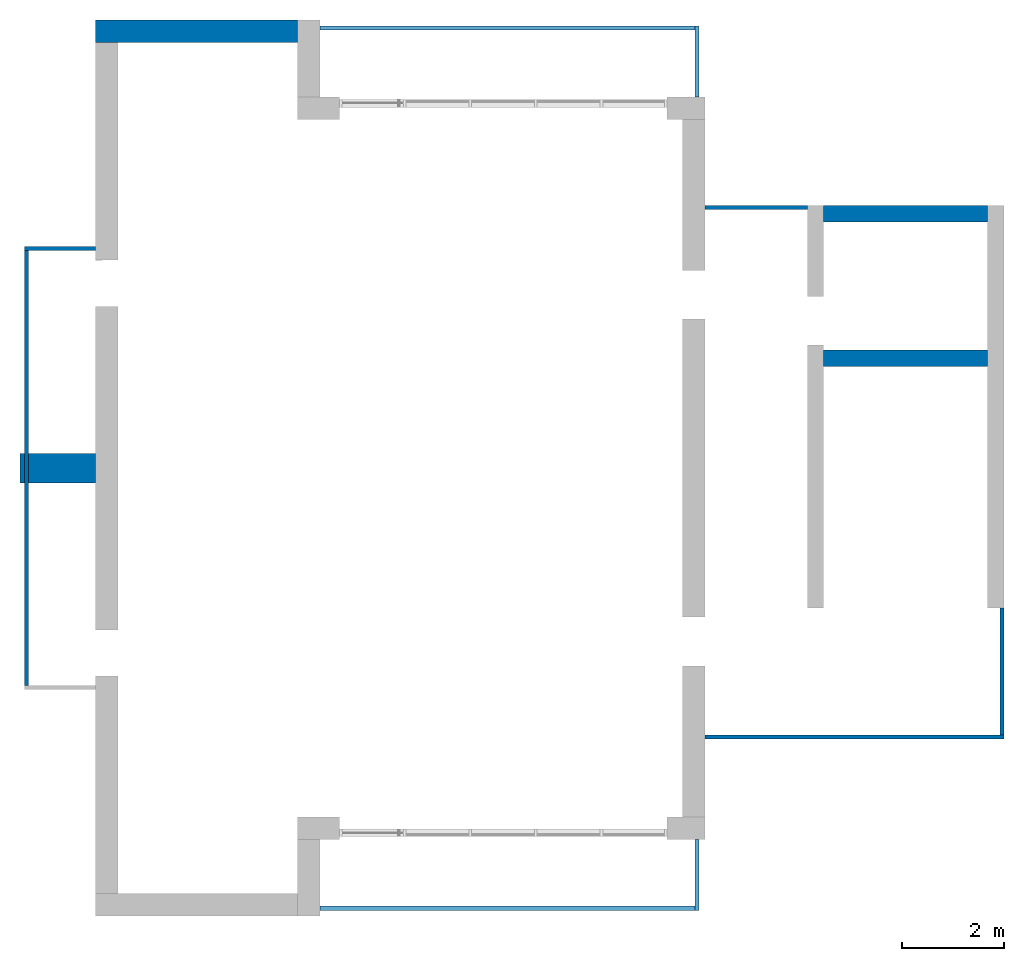
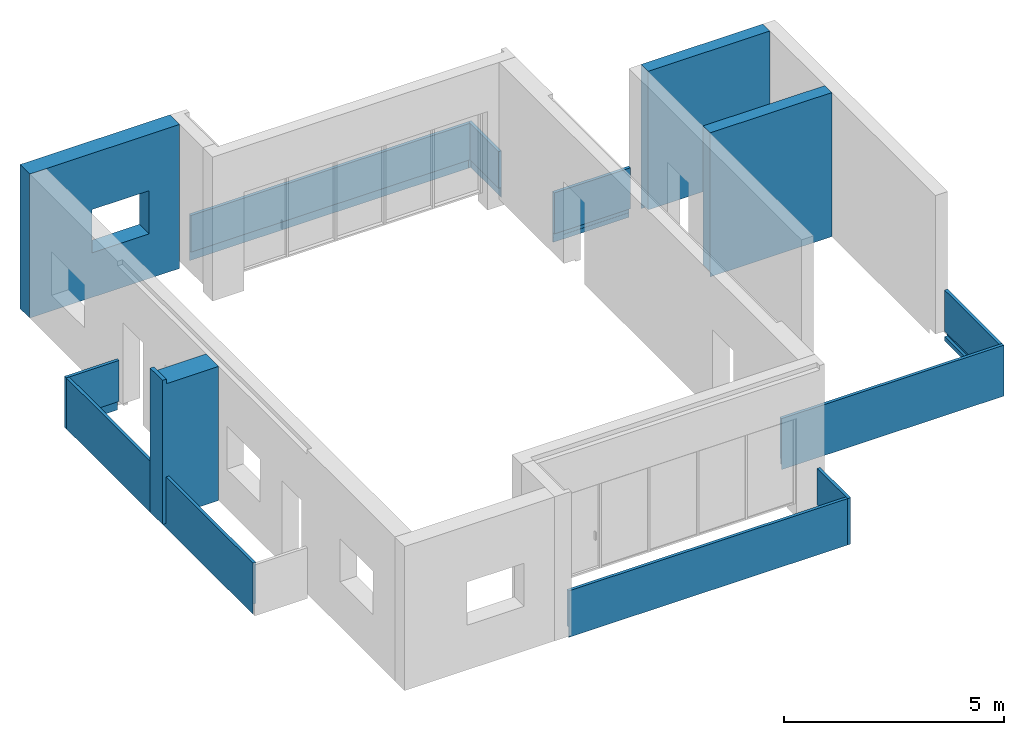
# One storey, part 2 of 4: 13 walls, 1 opening.
"""IFC2X3 building model written with IfcOpenShell, lengths in millimetres."""

from ifc_helpers import new_model, entity, si_unit, converted_unit, derived_unit, direction, frame, frame_2d, origin, place, context, subcontext, project, spatial, polyline, rectangle, extrude, clip, bounded_halfspace, faceted_brep, material, layer, layer_set, layer_usage, type_object, element, save


model = new_model("IFC2X3")

# Units and contexts
model_context = context("Model", 3, precision=0.01, world=origin(), true_north=direction((6.12303176911189e-17, 1.0)))
body_context = subcontext(model_context, "Body", "Model", "MODEL_VIEW")
ifc_project = project(units=[si_unit("LENGTHUNIT", "METRE", prefix="MILLI"), si_unit("AREAUNIT", "SQUARE_METRE"), si_unit("VOLUMEUNIT", "CUBIC_METRE"), converted_unit("PLANEANGLEUNIT", "DEGREE", entity("IfcRatioMeasure", 0.0174532925199433), si_unit("PLANEANGLEUNIT", "RADIAN"), dimensions=[0, 0, 0, 0, 0, 0, 0]), si_unit("MASSUNIT", "GRAM", prefix="KILO"), derived_unit("MASSDENSITYUNIT", [(si_unit("MASSUNIT", "GRAM", prefix="KILO"), 1), (si_unit("LENGTHUNIT", "METRE"), -3)]), si_unit("TIMEUNIT", "SECOND"), si_unit("FREQUENCYUNIT", "HERTZ"), si_unit("THERMODYNAMICTEMPERATUREUNIT", "DEGREE_CELSIUS"), derived_unit("THERMALTRANSMITTANCEUNIT", [(si_unit("MASSUNIT", "GRAM", prefix="KILO"), 1), (si_unit("THERMODYNAMICTEMPERATUREUNIT", "KELVIN"), -1), (si_unit("TIMEUNIT", "SECOND"), -3)]), derived_unit("VOLUMETRICFLOWRATEUNIT", [(si_unit("LENGTHUNIT", "METRE"), 3), (si_unit("TIMEUNIT", "SECOND"), -1)]), si_unit("ELECTRICCURRENTUNIT", "AMPERE"), si_unit("ELECTRICVOLTAGEUNIT", "VOLT"), si_unit("POWERUNIT", "WATT"), si_unit("FORCEUNIT", "NEWTON", prefix="KILO"), si_unit("ILLUMINANCEUNIT", "LUX"), si_unit("LUMINOUSFLUXUNIT", "LUMEN"), si_unit("LUMINOUSINTENSITYUNIT", "CANDELA"), derived_unit("USERDEFINED", [(si_unit("MASSUNIT", "GRAM", prefix="KILO"), -1), (si_unit("LENGTHUNIT", "METRE"), -2), (si_unit("TIMEUNIT", "SECOND"), 3), (si_unit("LUMINOUSFLUXUNIT", "LUMEN"), 1)]), derived_unit("LINEARVELOCITYUNIT", [(si_unit("LENGTHUNIT", "METRE"), 1), (si_unit("TIMEUNIT", "SECOND"), -1)]), si_unit("PRESSUREUNIT", "PASCAL"), derived_unit("USERDEFINED", [(si_unit("LENGTHUNIT", "METRE"), -2), (si_unit("MASSUNIT", "GRAM", prefix="KILO"), 1), (si_unit("TIMEUNIT", "SECOND"), -2)])], contexts=[model_context])

# Site, building, storey
site_placement = place(None, origin())
site = spatial("IfcSite", under=ifc_project, at=site_placement, CompositionType="ELEMENT")
building_placement = place(site_placement, origin())
building = spatial("IfcBuilding", under=site, at=building_placement, CompositionType="ELEMENT")
storey_placement = place(building_placement, frame((0.0, 0.0, 4000.0)))
storey = spatial("IfcBuildingStorey", under=building, at=storey_placement, Name="01 Level", CompositionType="ELEMENT", Elevation=4000.0)

# Wall, opening
ifc_material_1 = material(Name="03")
ifc_layer_1 = layer(ifc_material_1, 10.0)
ifc_material_2 = material()
ifc_layer_2 = layer(ifc_material_2, 120.0)
ifc_material_3 = material()
ifc_layer_3 = layer(ifc_material_3, 300.0)
ifc_layer_4 = layer(ifc_material_1, 10.0)
ifc_layer_set_1 = layer_set([ifc_layer_1, ifc_layer_2, ifc_layer_3, ifc_layer_4], Name="Basic Wall:00_fal+12 cm")
ifc_layer_usage_1 = layer_usage(ifc_layer_set_1, "AXIS2", "POSITIVE", -220.0)
wall_type_1 = type_object("IfcWallType", Name="Basic Wall:00_fal+12 cm", PredefinedType="STANDARD", material=ifc_layer_set_1)
wall_1_placement = place(storey_placement, frame((20983.4900708518, -60301.2395851399, -340.0), z_axis=(0.0, 0.0, 1.0), x_axis=(-1.0, 0.0, 0.0)))
wall_1 = element("IfcWallStandardCase", 1, at=wall_1_placement, inside=storey, type_object=wall_type_1, material=ifc_layer_usage_1, Name="Basic Wall:00_fal+12 cm", ObjectType="Basic Wall:00_fal+12 cm", context=body_context, shape_type="SweptSolid", body=[
    extrude(rectangle(XDim=3940.00000000004, YDim=440.000000000004, at=frame_2d((1970.00000000002, -1.08002495835535e-12), x_axis=(-1.0, 0.0))), origin(), (0.0, 0.0, 1.0), 4000.0),
])
opening_placement = place(wall_1_placement, frame((2300.0, 1304.0, 1240.0), z_axis=(0.0, 0.0, 1.0), x_axis=(-1.0, 0.0, 0.0)))
element("IfcOpeningElement", 2, at=opening_placement, cuts=wall_1, Name="Basic Wall:00_fal+12 cm", ObjectType="Opening", context=body_context, shape_type="SweptSolid", body=[
    extrude(rectangle(XDim=1200.0, YDim=1500.0, at=frame_2d((1.08002495835535e-12, -5.11590769747272e-13), x_axis=(0.0, 1.0))), frame((750.0, 3048.0, 600.0), z_axis=(0.0, -1.0, 0.0), x_axis=(1.0, 0.0, 0.0)), (0.0, 0.0, 1.0), 3048.0),
])

# Walls
ifc_layer_5 = layer(ifc_material_1, 10.0)
ifc_layer_6 = layer(ifc_material_3, 300.0)
ifc_layer_7 = layer(ifc_material_1, 10.0)
ifc_layer_set_2 = layer_set([ifc_layer_5, ifc_layer_6, ifc_layer_7], Name="Basic Wall:00_fal 300 mm")
ifc_layer_usage_2 = layer_usage(ifc_layer_set_2, "AXIS2", "NEGATIVE", 160.0)
wall_type_2 = type_object("IfcWallType", Name="Basic Wall:00_fal 300 mm", PredefinedType="STANDARD", material=ifc_layer_set_2)
wall_2_placement = place(storey_placement, frame((31263.4900708518, -66685.8241905964, -340.0)))
element("IfcWallStandardCase", 3, at=wall_2_placement, inside=storey, type_object=wall_type_2, material=ifc_layer_usage_2, Name="Basic Wall:00_fal 300 mm", ObjectType="Basic Wall:00_fal 300 mm", context=body_context, shape_type="Clipping", body=[
    clip(clip(extrude(rectangle(XDim=3199.99999999998, YDim=319.999999999997, at=frame_2d((1599.99999999999, 1.406874616805e-12), x_axis=(-1.0, 0.0))), origin(), (0.0, 0.0, 1.0), 4000.0), bounded_halfspace(frame((3200.0, -150.0, 150.0), z_axis=(0.0, 0.0, 1.0), x_axis=(0.0, 1.0, 0.0)), True, frame((3200.0, -150.0, 150.0), z_axis=(0.0, 0.0, 1.0), x_axis=(0.0, 1.0, 0.0)), polyline([(0.0, 0.0), (310.0, 0.0), (310.0, 3200.0), (0.0, 3200.0), (0.0, 0.0)]))), bounded_halfspace(frame((0.0, -150.0, 150.0), z_axis=(0.0, -1.0, 0.0), x_axis=(0.0, 0.0, 1.0)), True, frame((0.0, -150.0, 150.0), z_axis=(0.0, -1.0, 0.0), x_axis=(0.0, 0.0, 1.0)), polyline([(0.0, 0.0), (-150.0, 0.0), (-150.0, -3200.0), (0.0, -3200.0), (0.0, 0.0)]))),
])
ifc_layer_usage_3 = layer_usage(ifc_layer_set_2, "AXIS2", "NEGATIVE", 160.0)
wall_3_placement = place(storey_placement, frame((31263.4900708518, -63865.8241905964, -340.0)))
element("IfcWallStandardCase", 4, at=wall_3_placement, inside=storey, type_object=wall_type_2, material=ifc_layer_usage_3, Name="Basic Wall:00_fal 300 mm", ObjectType="Basic Wall:00_fal 300 mm", context=body_context, shape_type="Clipping", body=[
    clip(clip(extrude(rectangle(XDim=3199.99999999998, YDim=319.999999999997, at=frame_2d((1599.99999999999, 0.0), x_axis=(-1.0, 0.0))), origin(), (0.0, 0.0, 1.0), 4000.0), bounded_halfspace(frame((0.0, 150.0, 150.0), z_axis=(0.0, 0.0, 1.0), x_axis=(0.0, 1.0, 0.0)), True, frame((0.0, 150.0, 150.0), z_axis=(0.0, 0.0, 1.0), x_axis=(0.0, 1.0, 0.0)), polyline([(0.0, 0.0), (-310.0, 0.0), (-310.0, -3200.0), (-5.0, -3200.0), (0.0, -3200.0), (0.0, 0.0)]))), bounded_halfspace(frame((3200.0, 150.0, 150.0), z_axis=(0.0, 1.0, 0.0), x_axis=(0.0, 0.0, 1.0)), True, frame((3200.0, 150.0, 150.0), z_axis=(0.0, 1.0, 0.0), x_axis=(0.0, 0.0, 1.0)), polyline([(0.0, 0.0), (-150.0, 0.0), (-150.0, -3200.0), (0.0, -3200.0), (0.0, 0.0)]))),
])
ifc_layer_8 = layer(ifc_material_1, 10.0)
ifc_material_4 = material(Name="06_ APP")
ifc_layer_9 = layer(ifc_material_4, 10.0)
ifc_layer_10 = layer(ifc_material_2, 120.0)
ifc_layer_11 = layer(ifc_material_3, 300.0)
ifc_material_5 = material()
ifc_layer_12 = layer(ifc_material_5, 120.0)
ifc_layer_13 = layer(ifc_material_1, 10.0)
ifc_layer_set_3 = layer_set([ifc_layer_8, ifc_layer_9, ifc_layer_10, ifc_layer_11, ifc_layer_12, ifc_layer_13], Name="Basic Wall:00_fal+2x12 cm")
ifc_layer_usage_4 = layer_usage(ifc_layer_set_3, "AXIS2", "NEGATIVE", 285.0)
wall_type_3 = type_object("IfcWallType", Name="Basic Wall:00_fal+2x12 cm", PredefinedType="STANDARD", material=ifc_layer_set_3)
wall_4_placement = place(storey_placement, frame((17043.4900708518, -68836.2395851399, -340.0), z_axis=(0.0, 0.0, 1.0), x_axis=(-1.0, 0.0, 0.0)))
element("IfcWallStandardCase", 5, at=wall_4_placement, inside=storey, type_object=wall_type_3, material=ifc_layer_usage_4, Name="Basic Wall:00_fal+2x12 cm", ObjectType="Basic Wall:00_fal+2x12 cm", context=body_context, shape_type="Clipping", body=[
    clip(clip(clip(clip(extrude(rectangle(XDim=1474.99999999999, YDim=569.999999999992, at=frame_2d((737.499999999994, -5.6843418860808e-13), x_axis=(-1.0, 0.0))), origin(), (0.0, 0.0, 1.0), 4000.0), bounded_halfspace(frame((1370.0, 285.0, 150.0)), True, frame((1370.0, 285.0, 150.0)), polyline([(0.0, 0.0), (-1370.0, 0.0), (-1370.0, -570.0), (0.0, -570.0), (0.0, 0.0)]))), bounded_halfspace(frame((1370.0, -285.0, 150.0), z_axis=(1.0, 0.0, 0.0), x_axis=(0.0, 0.0, 1.0)), True, frame((1370.0, -285.0, 150.0), z_axis=(1.0, 0.0, 0.0), x_axis=(0.0, 0.0, 1.0)), polyline([(0.0, 0.0), (-150.0, 0.0), (-150.0, -570.0), (0.0, -570.0), (0.0, 0.0)]))), bounded_halfspace(frame((1370.0, -285.0, 3875.0), z_axis=(0.0, 0.0, -1.0), x_axis=(-1.0, 0.0, 0.0)), True, frame((1370.0, -285.0, 3875.0), z_axis=(0.0, 0.0, -1.0), x_axis=(-1.0, 0.0, 0.0)), polyline([(0.0, 0.0), (1370.0, 0.0), (1370.0, 570.0), (0.0, 570.0), (0.0, 0.0)]))), bounded_halfspace(frame((1370.0, 285.0, 3875.0), z_axis=(1.0, 0.0, 0.0), x_axis=(0.0, 0.0, 1.0)), True, frame((1370.0, 285.0, 3875.0), z_axis=(1.0, 0.0, 0.0), x_axis=(0.0, 0.0, 1.0)), polyline([(0.0, 0.0), (125.0, 0.0), (125.0, 570.0), (0.0, 570.0), (0.0, 0.0)]))),
])
ifc_material_6 = material(Name="03")
ifc_layer_14 = layer(ifc_material_6, 15.0)
ifc_material_7 = material(Name="02_C40/55")
ifc_layer_15 = layer(ifc_material_7, 50.0)
ifc_layer_16 = layer(ifc_material_6, 15.0)
ifc_layer_set_4 = layer_set([ifc_layer_14, ifc_layer_15, ifc_layer_16], Name="Basic Wall:00_fal")
ifc_layer_usage_5 = layer_usage(ifc_layer_set_4, "AXIS2", "NEGATIVE", 40.0)
wall_type_4 = type_object("IfcWallType", Name="Basic Wall:00_fal", PredefinedType="STANDARD", material=ifc_layer_set_4)
wall_5_placement = place(storey_placement, frame((28788.4900708518, -76081.2395851399, -465.0), z_axis=(0.0, 0.0, 1.0), x_axis=(0.0, -1.0, 0.0)))
element("IfcWallStandardCase", 6, at=wall_5_placement, inside=storey, type_object=wall_type_4, material=ifc_layer_usage_5, Name="Basic Wall:00_fal", ObjectType="Basic Wall:00_fal", context=body_context, shape_type="Clipping", body=[
    clip(clip(clip(extrude(rectangle(XDim=1384.99999999999, YDim=79.9999999999991, at=frame_2d((692.499999999994, 0.0), x_axis=(-1.0, 0.0))), origin(), (0.0, 0.0, 1.0), 1290.0), bounded_halfspace(frame((1370.0, 25.0, 275.0), z_axis=(0.0, 1.0, 0.0), x_axis=(0.0, 0.0, 1.0)), True, frame((1370.0, 25.0, 275.0), z_axis=(0.0, 1.0, 0.0), x_axis=(0.0, 0.0, 1.0)), polyline([(0.0, 0.0), (-150.0, 0.0), (-275.0, 0.0), (-275.0, -1370.0), (0.0, -1370.0), (0.0, 0.0)]))), bounded_halfspace(frame((1370.0, 25.0, 275.0), z_axis=(1.0, 0.0, 0.0), x_axis=(0.0, 0.0, 1.0)), True, frame((1370.0, 25.0, 275.0), z_axis=(1.0, 0.0, 0.0), x_axis=(0.0, 0.0, 1.0)), polyline([(0.0, 0.0), (0.0, 65.0), (-275.0, 65.0), (-275.0, 0.0), (-150.0, 0.0), (0.0, 0.0)]))), bounded_halfspace(frame((0.0, 25.0, 275.0), z_axis=(0.0, 0.0, 1.0), x_axis=(0.0, -1.0, 0.0)), True, frame((0.0, 25.0, 275.0), z_axis=(0.0, 0.0, 1.0), x_axis=(0.0, -1.0, 0.0)), polyline([(0.0, 0.0), (65.0, 0.0), (65.0, 1305.0), (65.0, 1370.0), (0.0, 1370.0), (0.0, 0.0)]))),
])
ifc_layer_usage_6 = layer_usage(ifc_layer_set_4, "AXIS2", "NEGATIVE", 40.0)
wall_6_placement = place(storey_placement, frame((28748.4900708518, -77426.2395851399, -465.0), z_axis=(0.0, 0.0, 1.0), x_axis=(-1.0, 0.0, 0.0)))
element("IfcWallStandardCase", 7, at=wall_6_placement, inside=storey, type_object=wall_type_4, material=ifc_layer_usage_6, Name="Basic Wall:00_fal", ObjectType="Basic Wall:00_fal", context=body_context, shape_type="Clipping", body=[
    clip(clip(extrude(rectangle(XDim=7325.0, YDim=79.9999999999991, at=frame_2d((3662.5, 0.0), x_axis=(-1.0, 0.0))), origin(), (0.0, 0.0, 1.0), 1290.0), bounded_halfspace(frame((7325.0, -40.0, 275.0)), True, frame((7325.0, -40.0, 275.0)), polyline([(0.0, 0.0), (0.0, 65.0), (-7325.0, 65.0), (-7325.0, 0.0), (0.0, 0.0)]))), bounded_halfspace(frame((0.0, 25.0, 0.0), z_axis=(0.0, 1.0, 0.0), x_axis=(0.0, 0.0, 1.0)), True, frame((0.0, 25.0, 0.0), z_axis=(0.0, 1.0, 0.0), x_axis=(0.0, 0.0, 1.0)), polyline([(0.0, 0.0), (275.0, 0.0), (275.0, 7325.0), (0.0, 7325.0), (0.0, 0.0)]))),
])
ifc_layer_usage_7 = layer_usage(ifc_layer_set_4, "AXIS2", "NEGATIVE", 40.0)
wall_7_placement = place(storey_placement, frame((15698.4900708517, -73076.2395851399, -465.0), z_axis=(0.0, 0.0, 1.0), x_axis=(0.0, 1.0, 0.0)))
element("IfcWallStandardCase", 8, at=wall_7_placement, inside=storey, type_object=wall_type_4, material=ifc_layer_usage_7, Name="Basic Wall:00_fal", ObjectType="Basic Wall:00_fal", context=body_context, shape_type="Clipping", body=[
    clip(clip(extrude(rectangle(XDim=8489.99999999998, YDim=79.9999999999991, at=frame_2d((4244.99999999999, 3.48165940522449e-13), x_axis=(-1.0, 0.0))), origin(), (0.0, 0.0, 1.0), 1415.0), bounded_halfspace(frame((0.0, 25.0, 0.0), z_axis=(0.0, 1.0, 0.0), x_axis=(0.0, 0.0, 1.0)), True, frame((0.0, 25.0, 0.0), z_axis=(0.0, 1.0, 0.0), x_axis=(0.0, 0.0, 1.0)), polyline([(0.0, 0.0), (125.0, 0.0), (275.0, 0.0), (275.0, 8490.0), (125.0, 8490.0), (0.0, 8490.0), (0.0, 0.0)]))), bounded_halfspace(frame((0.0, 25.0, 275.0), z_axis=(0.0, 0.0, 1.0), x_axis=(0.0, 1.0, 0.0)), True, frame((0.0, 25.0, 275.0), z_axis=(0.0, 0.0, 1.0), x_axis=(0.0, 1.0, 0.0)), polyline([(0.0, 0.0), (-65.0, 0.0), (-65.0, -8490.0), (0.0, -8490.0), (0.0, 0.0)]))),
])
ifc_layer_usage_8 = layer_usage(ifc_layer_set_4, "AXIS2", "POSITIVE", -40.0)
wall_8_placement = place(storey_placement, frame((17043.4900708518, -64546.2395851399, -465.0), z_axis=(0.0, 0.0, 1.0), x_axis=(-1.0, 0.0, 0.0)))
element("IfcWallStandardCase", 9, at=wall_8_placement, inside=storey, type_object=wall_type_4, material=ifc_layer_usage_8, Name="Basic Wall:00_fal", ObjectType="Basic Wall:00_fal", context=body_context, shape_type="Clipping", body=[
    clip(clip(clip(extrude(rectangle(XDim=1385.00000000003, YDim=79.9999999999991, at=frame_2d((692.500000000013, -1.73372427525464e-12), x_axis=(-1.0, 0.0))), origin(), (0.0, 0.0, 1.0), 1415.0), bounded_halfspace(frame((1370.0, -25.0, 275.0), z_axis=(1.0, 0.0, 0.0), x_axis=(0.0, 0.0, 1.0)), True, frame((1370.0, -25.0, 275.0), z_axis=(1.0, 0.0, 0.0), x_axis=(0.0, 0.0, 1.0)), polyline([(0.0, 0.0), (-150.0, 0.0), (-275.0, 0.0), (-275.0, -65.0), (0.0, -65.0), (0.0, 0.0)]))), bounded_halfspace(frame((1370.0, -25.0, 275.0), z_axis=(0.0, -1.0, 0.0), x_axis=(0.0, 0.0, 1.0)), True, frame((1370.0, -25.0, 275.0), z_axis=(0.0, -1.0, 0.0), x_axis=(0.0, 0.0, 1.0)), polyline([(0.0, 0.0), (0.0, 1370.0), (-150.0, 1370.0), (-275.0, 1370.0), (-275.0, 0.0), (-150.0, 0.0), (0.0, 0.0)]))), bounded_halfspace(frame((1370.0, 40.0, 275.0)), True, frame((1370.0, 40.0, 275.0)), polyline([(0.0, 0.0), (-65.0, 0.0), (-1370.0, 0.0), (-1370.0, -65.0), (0.0, -65.0), (0.0, 0.0)]))),
])
wall_9_placement = place(storey_placement, frame((28788.4900708518, -61581.23958514, -465.0), z_axis=(0.0, 0.0, 1.0), x_axis=(0.0, 1.0, 0.0)))
element("IfcWall", 10, at=wall_9_placement, inside=storey, type_object=wall_type_4, Name="Basic Wall:00_fal", ObjectType="Basic Wall:00_fal", context=body_context, shape_type="Brep", body=[
    faceted_brep([(0.0, -40.0, 0.0), (1385.0, -40.0, 0.0), (1385.0, -40.0, 1290.0), (0.0, -40.0, 1290.0), (0.0, 40.0, 1290.0), (1305.0, 40.0, 1290.0), (1385.0, 40.0, 1290.0), (1385.0, 40.0, 0.0), (1370.0, 40.0, 0.0), (1370.0, 40.0, 275.0), (1305.0, 40.0, 275.0), (0.0, 40.0, 275.0), (0.0, -25.0, 0.0), (1370.0, -25.0, 0.0), (0.0, -25.0, 275.0), (1370.0, -25.0, 275.0), (1370.0, -25.0, 125.0)], [[[0, 1, 2, 3]], [[4, 5, 6, 7, 8, 9, 10, 11]], [[1, 0, 12, 13, 8, 7]], [[3, 2, 6, 5, 4]], [[2, 1, 7, 6]], [[0, 3, 4, 11, 14, 12]], [[9, 15, 14, 11, 10]], [[15, 9, 8, 13, 16]], [[15, 16, 13, 12, 14]]]),
])
ifc_layer_usage_9 = layer_usage(ifc_layer_set_4, "AXIS2", "POSITIVE", -40.0)
wall_10_placement = place(storey_placement, frame((28748.4900708518, -60236.23958514, -465.0), z_axis=(0.0, 0.0, 1.0), x_axis=(-1.0, 0.0, 0.0)))
element("IfcWallStandardCase", 11, at=wall_10_placement, inside=storey, type_object=wall_type_4, material=ifc_layer_usage_9, Name="Basic Wall:00_fal", ObjectType="Basic Wall:00_fal", context=body_context, shape_type="Clipping", body=[
    clip(clip(extrude(rectangle(XDim=7325.0, YDim=79.9999999999991, at=frame_2d((3662.5, 4.9382720135327e-13), x_axis=(-1.0, 0.0))), origin(), (0.0, 0.0, 1.0), 1290.0), bounded_halfspace(frame((7325.0, -25.0, 275.0)), True, frame((7325.0, -25.0, 275.0)), polyline([(0.0, 0.0), (0.0, 65.0), (-7325.0, 65.0), (-7325.0, 0.0), (0.0, 0.0)]))), bounded_halfspace(frame((0.0, -25.0, 275.0), z_axis=(0.0, -1.0, 0.0), x_axis=(0.0, 0.0, 1.0)), True, frame((0.0, -25.0, 275.0), z_axis=(0.0, -1.0, 0.0), x_axis=(0.0, 0.0, 1.0)), polyline([(0.0, 0.0), (-275.0, 0.0), (-275.0, -7325.0), (0.0, -7325.0), (0.0, 0.0)]))),
])
wall_11_placement = place(storey_placement, frame((34783.4900708518, -74085.8241905963, -465.0), z_axis=(0.0, 0.0, 1.0), x_axis=(-1.0, 0.0, 0.0)))
element("IfcWall", 12, at=wall_11_placement, inside=storey, type_object=wall_type_4, Name="Basic Wall:00_fal", ObjectType="Basic Wall:00_fal", context=body_context, shape_type="Brep", body=[
    faceted_brep([(5840.0, -40.0, 1415.0), (80.0, -40.0, 1415.0), (0.0, -40.0, 1415.0), (0.0, -40.0, 0.0), (10.0, -40.0, 0.0), (10.0, -40.0, 125.0), (10.0, -40.0, 275.0), (80.0, -40.0, 275.0), (5840.0, -40.0, 275.0), (5840.0, -40.0, 465.0), (5840.0, 40.0, 0.0), (0.0, 40.0, 0.0), (0.0, 40.0, 1415.0), (5840.0, 40.0, 1415.0), (5840.0, 30.0, 0.0), (10.0, 30.0, 0.0), (5840.0, -25.0, 275.0), (5840.0, -25.0, 125.0), (5840.0, 30.0, 125.0), (10.0, -25.0, 275.0), (10.0, -25.0, 125.0), (10.0, 30.0, 125.0)], [[[0, 1, 2, 3, 4, 5, 6, 7, 8, 9]], [[10, 11, 12, 13]], [[11, 10, 14, 15, 4, 3]], [[10, 13, 0, 9, 8, 16, 17, 18, 14]], [[2, 1, 0, 13, 12]], [[3, 2, 12, 11]], [[6, 19, 16, 8, 7]], [[20, 19, 6, 5, 4, 15, 21]], [[19, 20, 17, 16]], [[20, 21, 18, 17]], [[21, 15, 14, 18]]]),
])
ifc_layer_usage_10 = layer_usage(ifc_layer_set_4, "AXIS2", "NEGATIVE", 40.0)
wall_12_placement = place(storey_placement, frame((30943.4900708518, -63745.8241905964, -465.0), z_axis=(0.0, 0.0, 1.0), x_axis=(-1.0, 0.0, 0.0)))
element("IfcWallStandardCase", 13, at=wall_12_placement, inside=storey, type_object=wall_type_4, material=ifc_layer_usage_10, Name="Basic Wall:00_fal", ObjectType="Basic Wall:00_fal", context=body_context, shape_type="Clipping", body=[
    clip(clip(extrude(rectangle(XDim=2000.00000000002, YDim=79.9999999999991, at=frame_2d((1000.00000000001, 0.0), x_axis=(-1.0, 0.0))), origin(), (0.0, 0.0, 1.0), 1415.0), bounded_halfspace(frame((0.0, -30.0, 275.0), z_axis=(0.0, -1.0, 0.0), x_axis=(0.0, 0.0, 1.0)), True, frame((0.0, -30.0, 275.0), z_axis=(0.0, -1.0, 0.0), x_axis=(0.0, 0.0, 1.0)), polyline([(0.0, 0.0), (-150.0, 0.0), (-150.0, -2000.0), (0.0, -2000.0), (0.0, 0.0)]))), bounded_halfspace(frame((2000.0, -25.0, 0.0), z_axis=(0.0, -1.0, 0.0), x_axis=(0.0, 0.0, 1.0)), True, frame((2000.0, -25.0, 0.0), z_axis=(0.0, -1.0, 0.0), x_axis=(0.0, 0.0, 1.0)), polyline([(0.0, 0.0), (125.0, 0.0), (125.0, 2000.0), (0.0, 2000.0), (0.0, 0.0)]))),
])
ifc_layer_usage_11 = layer_usage(ifc_layer_set_4, "AXIS2", "NEGATIVE", 40.0)
wall_13_placement = place(storey_placement, frame((34743.4900708518, -71560.8241905963, -465.0), z_axis=(0.0, 0.0, 1.0), x_axis=(0.0, -1.0, 0.0)))
element("IfcWallStandardCase", 14, at=wall_13_placement, inside=storey, type_object=wall_type_4, material=ifc_layer_usage_11, Name="Basic Wall:00_fal", ObjectType="Basic Wall:00_fal", context=body_context, shape_type="Clipping", body=[
    clip(extrude(rectangle(XDim=2484.99999999999, YDim=79.9999999999991, at=frame_2d((1242.49999999999, 0.0), x_axis=(-1.0, 0.0))), origin(), (0.0, 0.0, 1.0), 1415.0), bounded_halfspace(frame((0.0, 30.0, 125.0), z_axis=(0.0, 1.0, 0.0), x_axis=(0.0, 0.0, 1.0)), True, frame((0.0, 30.0, 125.0), z_axis=(0.0, 1.0, 0.0), x_axis=(0.0, 0.0, 1.0)), polyline([(0.0, 0.0), (150.0, 0.0), (150.0, 2485.0), (0.0, 2485.0), (0.0, 0.0)]))),
])

save(model, "model.ifc")
